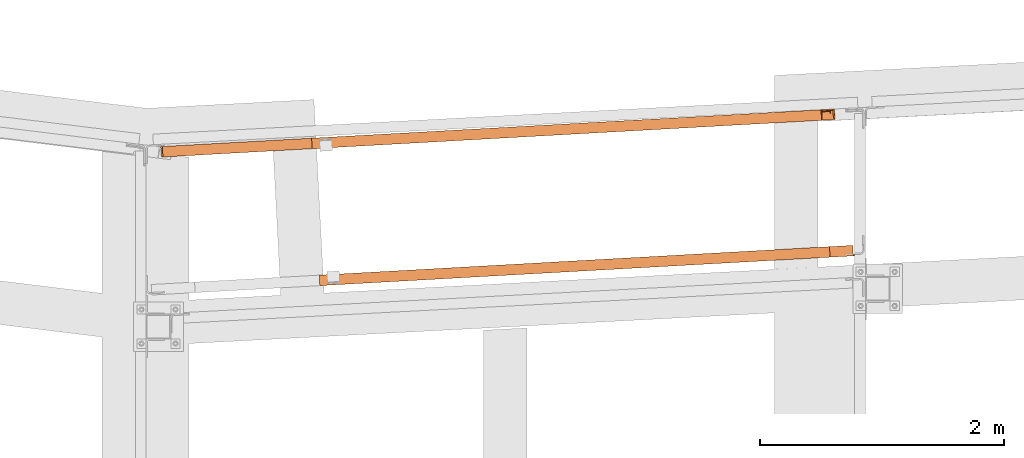
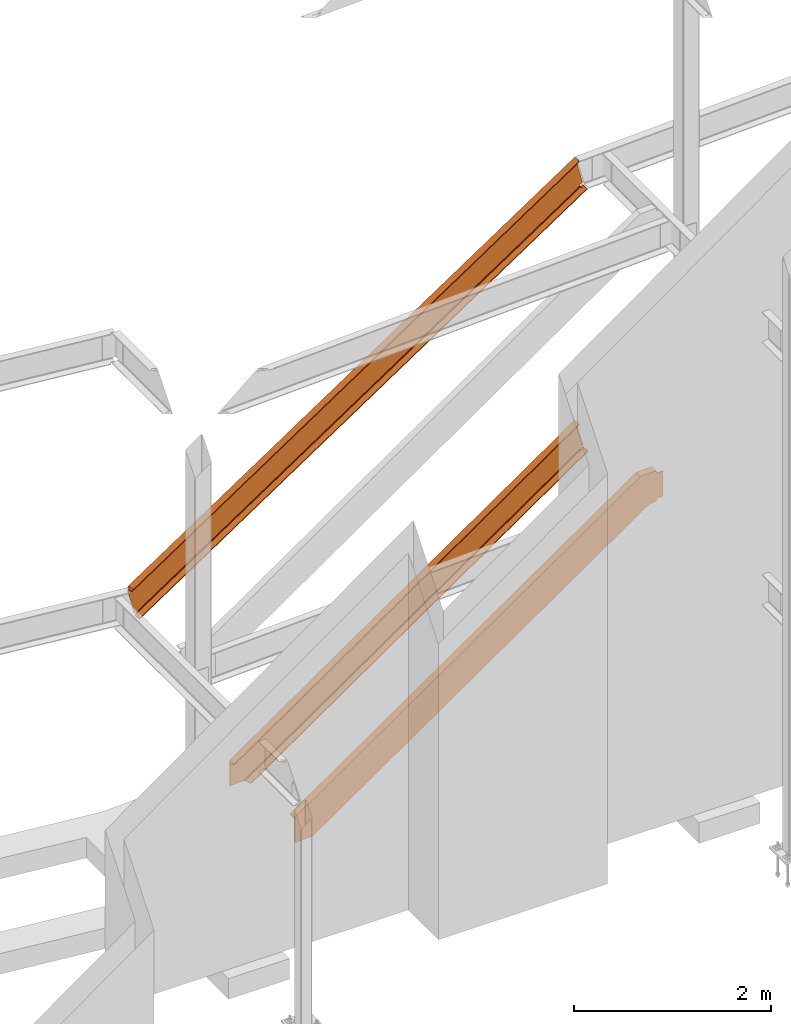
# One storey, part 19 of 89: 3 proxies.
"""IFC4 building model written with IfcOpenShell, lengths in feet."""

from ifc_helpers import new_model, entity, si_unit, converted_unit, derived_unit, direction, frame, origin, place, context, subcontext, project, spatial, face_set, faceted_brep, surface_model, source, transform, mapped, material, constituent, constituent_set, type_object, type_shapes, element, save


model = new_model("IFC4")

# Units and contexts
model_context = context("Model", 3, precision=0.0001, world=origin(), true_north=direction((6.12303176911189e-17, 1.0)))
body_context = subcontext(model_context, "Body", "Model", "MODEL_VIEW")
ifc_project = project(units=[converted_unit("LENGTHUNIT", "FOOT", entity("IfcRatioMeasure", 0.3048), si_unit("LENGTHUNIT", "METRE"), dimensions=[1, 0, 0, 0, 0, 0, 0]), converted_unit("AREAUNIT", "SQUARE FOOT", entity("IfcRatioMeasure", 0.09290304), si_unit("AREAUNIT", "SQUARE_METRE"), dimensions=[2, 0, 0, 0, 0, 0, 0]), converted_unit("VOLUMEUNIT", "CUBIC FOOT", entity("IfcRatioMeasure", 0.028316846592), si_unit("VOLUMEUNIT", "CUBIC_METRE"), dimensions=[3, 0, 0, 0, 0, 0, 0]), si_unit("PLANEANGLEUNIT", "RADIAN"), si_unit("MASSUNIT", "GRAM", prefix="KILO"), derived_unit("MASSDENSITYUNIT", [(si_unit("MASSUNIT", "GRAM", prefix="KILO"), 1), (si_unit("LENGTHUNIT", "METRE"), -3)]), derived_unit("MOMENTOFINERTIAUNIT", [(si_unit("LENGTHUNIT", "METRE"), 4)]), si_unit("TIMEUNIT", "SECOND"), si_unit("FREQUENCYUNIT", "HERTZ"), si_unit("THERMODYNAMICTEMPERATUREUNIT", "DEGREE_CELSIUS"), derived_unit("THERMALTRANSMITTANCEUNIT", [(si_unit("MASSUNIT", "GRAM", prefix="KILO"), 1), (si_unit("THERMODYNAMICTEMPERATUREUNIT", "KELVIN"), -1), (si_unit("TIMEUNIT", "SECOND"), -3)]), derived_unit("VOLUMETRICFLOWRATEUNIT", [(si_unit("LENGTHUNIT", "METRE"), 3), (si_unit("TIMEUNIT", "SECOND"), -1)]), si_unit("ELECTRICCURRENTUNIT", "AMPERE"), si_unit("ELECTRICVOLTAGEUNIT", "VOLT"), si_unit("POWERUNIT", "WATT"), si_unit("FORCEUNIT", "NEWTON"), si_unit("ILLUMINANCEUNIT", "LUX"), si_unit("LUMINOUSFLUXUNIT", "LUMEN"), si_unit("LUMINOUSINTENSITYUNIT", "CANDELA"), derived_unit("USERDEFINED", [(si_unit("MASSUNIT", "GRAM", prefix="KILO"), -1), (si_unit("LENGTHUNIT", "METRE"), -2), (si_unit("TIMEUNIT", "SECOND"), 3), (si_unit("LUMINOUSFLUXUNIT", "LUMEN"), 1)]), derived_unit("LINEARVELOCITYUNIT", [(si_unit("LENGTHUNIT", "METRE"), 1), (si_unit("TIMEUNIT", "SECOND"), -1)]), si_unit("PRESSUREUNIT", "PASCAL"), derived_unit("USERDEFINED", [(si_unit("LENGTHUNIT", "METRE"), -2), (si_unit("MASSUNIT", "GRAM", prefix="KILO"), 1), (si_unit("TIMEUNIT", "SECOND"), -2)]), derived_unit("LINEARFORCEUNIT", [(si_unit("MASSUNIT", "GRAM", prefix="KILO"), 1), (si_unit("LENGTHUNIT", "METRE"), 1), (si_unit("TIMEUNIT", "SECOND"), -2), (si_unit("LENGTHUNIT", "METRE"), -1)]), derived_unit("PLANARFORCEUNIT", [(si_unit("MASSUNIT", "GRAM", prefix="KILO"), 1), (si_unit("LENGTHUNIT", "METRE"), 1), (si_unit("TIMEUNIT", "SECOND"), -2), (si_unit("LENGTHUNIT", "METRE"), -2)])], contexts=[model_context])

# Site, building, storey
site_placement = place(None, origin())
site = spatial("IfcSite", under=ifc_project, at=site_placement, CompositionType="ELEMENT")
building_placement = place(site_placement, frame((-472.238160486, -49.138065117, 0.0)))
building = spatial("IfcBuilding", under=site, at=building_placement, CompositionType="ELEMENT")
storey_placement = place(building_placement, origin())
storey = spatial("IfcBuildingStorey", under=building, at=storey_placement, Name="Level 1", CompositionType="ELEMENT", Elevation=0.0)

# Proxies
ifc_material_1 = material(Name="Color 7720", Category="Materials")
ifc_material_2 = material()
ifc_constituent_1 = constituent(ifc_material_2)
ifc_constituent_2 = constituent(ifc_material_1, Name="Color 7720", Category="Materials")
ifc_constituent_set_1 = constituent_set(constituents=[ifc_constituent_1, ifc_constituent_2])
building_element_proxy_type_1 = type_object("IfcBuildingElementProxyType", Name="65B1", PredefinedType="NOTDEFINED", material=ifc_constituent_set_1)
shared_shape_1 = source(origin(), body_context, "Body", "SurfaceModel", [
    surface_model("IfcFaceBasedSurfaceModel", [(0.295725599131003, 0.298618076192042, 0.010066705292779), (0.298398827761901, 0.29876719922845, 0.0), (0.314179722650067, 0.0158736836889375, 0.0), (0.31150649401917, 0.0157245606525294, 0.010066705292779), (0.264968785703161, 0.263517185083515, 0.132880509864478), (0.00185657586928301, 0.248839767966842, 1.1236947801826), (0.0, 0.282121358030281, 1.1236947801826), (0.263112209833935, 0.296798775146954, 0.132880509864478), (17.7732027645449, 1.27357937755687, 11.858022026967), (17.7608547077558, 1.27289055517133, 11.9045216967659), (17.7766356026439, 0.989997039631817, 11.9045216967659), (17.7834019801254, 0.990374494348544, 11.8790412244943), (17.7819959007779, 1.11595072346483, 11.858022026967), (18.0571214415841, 1.28941745992006, 10.7888558449879), (17.7940092317501, 1.2747400428035, 11.779670115306), (17.7958658076193, 1.24145845274006, 11.779670115306), (18.0589780174533, 1.25613586985662, 10.7888558449879), (18.1055157257693, 1.00834324542575, 10.6660420404161), (18.1081889544002, 1.00849236846204, 10.6559753351234), (18.0924080595121, 1.29138588400156, 10.6559753351234), (18.0897348308811, 1.29123676096526, 10.6660420404161), (17.952139730053, 1.28356117384669, 10.7321324343652), (17.7619914226751, 1.2729539655262, 11.7546720500187), (17.7468636322483, 1.27211007884262, 11.7472027033928), (17.7300183363629, 1.27117038305914, 11.7463622836656), (17.7142242870842, 1.27028932987901, 11.7522889251786), (17.7020774498885, 1.26961173230075, 11.7640085042928), (17.6955743216495, 1.26924896264529, 11.7795947497751), (17.6957837793919, 1.26926064700854, 11.7964858515118), (17.7026713959043, 1.26964486490772, 11.8119055286269), (17.7151050983179, 1.27033846493771, 11.8233193487691), (17.7529728118764, 1.27245087252038, 11.909107345642), (0.0481609911819874, 0.284807964468314, 1.30654804508336), (0.00261789468112283, 0.282267394326936, 1.22773414158754), (0.00529112331201986, 0.282416517363458, 1.21766743629478), (0.0638364013074693, 0.285682399497546, 1.25282444181741), (0.0793525333193656, 0.286547949377223, 1.25833774725961), (0.0957890479889443, 0.287464841762812, 1.25739098436862), (0.110571787677145, 0.288289480180993, 1.25013242770127), (0.121385595973948, 0.288892716249393, 1.23769885530753), (0.126536899284361, 0.289180075879813, 1.22203751549417), (0.125218941003766, 0.289106555067406, 1.20560116411183), (0.117638129391082, 0.288683668063413, 1.19096393322691), (0.104981711531082, 0.287977644104103, 1.18041819080527), (0.295130018908878, 0.298584852424597, 0.157878575151766), (0.310252120444488, 0.299428421759785, 0.165346442812167), (0.327091489879081, 0.300367786942843, 0.16619014985198), (0.342882237877916, 0.301248655964855, 0.160271116242324), (0.355030712603536, 0.30192634489083, 0.148561551304688), (0.361541510557913, 0.302289542392714, 0.132984767007503), (0.361345224320985, 0.302278592786934, 0.116099271359211), (0.354474094174066, 0.301895294561064, 0.100678529987807), (0.342056712590022, 0.301202604970172, 0.0892554206389331), (0.341268695631754, 0.301158646335125, 0.088880608788596), (18.0460805163262, 1.28880155438719, 10.6914399093472), (17.9932897710816, 1.28585668235587, 10.6597290246742), (17.9777736865076, 1.28499113512237, 10.6542135610812), (17.9613363953122, 1.28407419941925, 10.6551585892483), (17.9465523881188, 1.28324949029468, 10.6624160941451), (17.9357372099552, 1.28264617780985, 10.6748493691158), (17.9305847880287, 1.28235875577866, 10.6905110525512), (17.9319021203893, 1.28243224167488, 10.7069481333881), (17.9394828798648, 1.28285512577042, 10.7215861539503), (18.0825023328435, 1.00705946932317, 10.6794311210408), (0.335515602523458, 0.0170638816224482, 0.0516152978580848), (18.0021084937518, 1.12776935737008, 10.6597290246741), (18.054871402101, 1.13121324275153, 10.6914399093471), (0.35005958140664, 0.143570334695823, 0.0888806087887808), (0.35087544796869, 0.143115052166877, 0.089255420639109), (0.362149245725277, 0.164308001823315, 0.100678529987992), (0.365777459588855, 0.222824884645433, 0.116099271359381), (0.365667356573624, 0.224882867314591, 0.116502267115274), (17.9646186250475, 1.2066204641643, 10.655666780207), (17.9659774283279, 1.20087751413507, 10.6551585892481), (17.985509222289, 1.14632137480237, 10.654213561081), (17.9570413472568, 1.22364703771746, 10.6589101283048), (0.364781271167942, 0.24228270146898, 0.123752648146477), (17.9456956444367, 1.23726656409883, 10.6663376948628), (0.362565075016676, 0.256411507056896, 0.136647436656453), (0.364360026038412, 0.251763906266206, 0.13298476700758), (17.9494507520763, 1.23129246408814, 10.6624160941452), (17.9362157395262, 1.24605132842385, 10.6795852555181), (0.354688001843442, 0.265285683537968, 0.150854856061752), (0.357170721441832, 0.263563842139092, 0.148561551304777), (17.9379314981277, 1.24331064584806, 10.6748493691159), (17.9331256234714, 1.24911533636339, 10.6990489358223), (0.338638484670298, 0.267626765939667, 0.162557775040209), (0.34478922504843, 0.267063376322653, 0.160271116242352), (17.9325103468877, 1.24784055393593, 10.6905110525512), (17.9413394557196, 1.24957353596494, 10.7215861539503), (17.9539963059078, 1.25027958404155, 10.7321324343652), (17.7638479985309, 1.23967237570389, 11.7546720500187), (17.7487202081041, 1.23882848901997, 11.7472027033928), (17.7318749122188, 1.23788879323592, 11.7463622836656), (17.7221975030833, 1.23734894990946, 11.7499936851959), (0.127709027826711, 0.255860304436851, 1.21350172405842), (0.12707551688743, 0.255824964745443, 1.20560116411183), (0.119494705274747, 0.255402077741337, 1.19096393322691), (0.106838287414746, 0.254696053781686, 1.18041819080527), (0.296986594791576, 0.265303262119346, 0.157878575151768), (0.312108696327186, 0.266146831454989, 0.165346442812167), (0.328948065761722, 0.267086196638616, 0.16619014985198), (17.9337586962442, 1.24915065186929, 10.7069481333881), (17.7065093281335, 1.23323741600052, 11.7616974341864), (0.124979036085108, 0.252471628622288, 1.23296550504353), (0.128462439435964, 0.254662209392791, 1.22203751549416), (17.7161314299826, 1.23610125860705, 11.7522889251786), (17.6996683184155, 1.22354220790703, 11.7759049678167), (0.116535035054028, 0.242686999470948, 1.24621308436147), (0.123579794613761, 0.249558789283356, 1.23769885530749), (17.7042182206326, 1.2312355713749, 11.7640085042928), (17.6990355348262, 1.20925447520597, 11.7887986985157), (0.10677429795129, 0.227890074204311, 1.25364052321855), (0.113469935967544, 0.236336320096484, 1.2501324277012), (17.6983946965211, 1.21868999446235, 11.7795947497751), (17.7000958529101, 1.19186436042446, 11.7960524737729), (0.101138442234117, 0.210126420938877, 1.25688428241156), (17.7103520069585, 1.13195971243556, 11.8119055277782), (17.7239238253192, 1.11225107143321, 11.8233193479195), (0.0296228440811319, 0.0, 1.24715775758312), (0.0147554209531222, 0.0646860958185016, 1.22773414232155), (0.0140820086414237, 0.124828205841709, 1.21766743702795), (0.0726551259076018, 0.127595032102363, 1.25282444254534), (0.0870874438550118, 0.147889389620673, 1.25833774798595), (0.100429091568628, 0.2042858856571, 1.25739098509289), (17.7002246112936, 1.18965284189335, 11.7964858506631), (17.7687537067645, 0.989557356982345, 11.909107345642), (0.0639418860702676, 0.00191444892675463, 1.30654804508337)], [face_set([[[0, 1, 2, 3]], [[4, 5, 6, 7]], [[8, 9, 10, 11, 12]], [[13, 14, 15, 16]], [[17, 18, 19, 20]], [[21, 13, 14, 22, 23, 24, 25, 26, 27, 28, 29, 30, 8, 9, 31, 32, 33, 34, 35, 36, 37, 38, 39, 40, 41, 42, 43, 6, 7, 44, 45, 46, 47, 48, 49, 50, 51, 52, 53, 0, 1, 19, 20, 54, 55, 56, 57, 58, 59, 60, 61, 62]], [[18, 2, 1, 19]], [[17, 63, 64, 3, 2, 18]], [[65, 66, 63, 64, 67, 68, 69, 70, 71, 72, 73, 74]], [[75, 76, 71, 72]], [[77, 78, 79, 76, 75, 80]], [[81, 82, 83, 78, 77, 84]], [[85, 86, 87, 82, 81, 88]], [[89, 90, 16, 15, 91, 92, 93, 94, 95, 96, 97, 98, 5, 4, 99, 100, 101, 86, 85, 102]], [[103, 104, 105, 95, 94, 106]], [[107, 108, 109, 104, 103, 110]], [[111, 112, 113, 108, 107, 114]], [[115, 116, 112, 111]], [[117, 118, 12, 11, 119, 120, 121, 122, 123, 124, 116, 115, 125]], [[126, 127, 119, 11, 10]], [[31, 32, 127, 126]], [[98, 43, 6, 5]], [[97, 42, 43, 98]], [[96, 41, 42, 97]], [[105, 40, 41, 96, 95]], [[109, 39, 40, 105, 104]], [[113, 38, 39, 109, 108]], [[116, 124, 37, 38, 113, 112]], [[123, 36, 37, 124]], [[36, 123, 122, 35]], [[35, 122, 121, 34]], [[120, 33, 34, 121]], [[127, 32, 33, 120, 119]], [[64, 67, 53, 0, 3]], [[68, 52, 53, 67]], [[69, 51, 52, 68]], [[70, 50, 51, 69]], [[76, 79, 49, 50, 70, 71]], [[83, 48, 49, 79, 78]], [[87, 47, 48, 83, 82]], [[101, 46, 47, 87, 86]], [[46, 101, 100, 45]], [[45, 100, 99, 44]], [[44, 99, 4, 7]], [[31, 126, 10, 9]], [[118, 30, 8, 12]], [[117, 29, 30, 118]], [[125, 28, 29, 117]], [[111, 114, 27, 28, 125, 115]], [[110, 26, 27, 114, 107]], [[106, 25, 26, 110, 103]], [[93, 24, 25, 106, 94]], [[24, 93, 92, 23]], [[23, 92, 91, 22]], [[22, 91, 15, 14]], [[16, 90, 21, 13]], [[89, 62, 21, 90]], [[102, 61, 62, 89]], [[88, 60, 61, 102, 85]], [[84, 59, 60, 88, 81]], [[80, 58, 59, 84, 77]], [[72, 73, 57, 58, 80, 75]], [[74, 56, 57, 73]], [[56, 74, 65, 55]], [[55, 65, 66, 54]], [[54, 66, 63, 17, 20]]])]),
])
type_shapes(building_element_proxy_type_1, [shared_shape_1])
proxy_1_placement = place(building_placement, frame((288.890091003621, 1017.17702823538, 8.3475913766196)))
element("IfcBuildingElementProxy", 1, at=proxy_1_placement, inside=storey, type_object=building_element_proxy_type_1, material=ifc_material_1, Name="65B1:65B1", ObjectType="65B1:65B1", PredefinedType="NOTDEFINED", context=body_context, shape_type="MappedRepresentation", body=[
    mapped(shared_shape_1, transform((0.0, 0.0, 0.0), scale=1.0)),
])
ifc_constituent_3 = constituent(ifc_material_2)
ifc_constituent_4 = constituent(ifc_material_1, Name="Color 7720", Category="Materials")
ifc_constituent_set_2 = constituent_set(constituents=[ifc_constituent_3, ifc_constituent_4])
building_element_proxy_type_2 = type_object("IfcBuildingElementProxyType", Name="c644", PredefinedType="NOTDEFINED", material=ifc_constituent_set_2)
shared_shape_2 = source(origin(), body_context, "Body", "Brep", [
    faceted_brep([(0.0, 0.28289351553849, 2.09684300217347e-07), (0.707232670482711, 0.322345690372117, 0.0), (0.723013565370877, 0.0394521748326042, 0.0), (0.66014500999637, 0.0359451235583492, 1.86396251559168e-08), (0.583988115515638, 0.237833801498596, 3.78203000407731e-08), (0.571363060839417, 0.25457879052567, 4.12757467593667e-08), (0.548317314991891, 0.267545643236417, 4.78734869618808e-08), (0.517667660340578, 0.275149477009677, 5.68071072481707e-08), (0.483160272312603, 0.276460907956448, 6.69846896448543e-08), (0.0018565758705904, 0.249611925475051, 2.09684300217337e-07), (13.7015000332585, 1.04721620219675, 9.58515138815906), (13.7172809281467, 0.764322686657238, 9.58515138815906), (13.7245293535907, 0.764727031874486, 9.55980424557848), (13.7235209223415, 0.89032544334043, 9.53889503357592), (13.7147277861084, 1.04795409743247, 9.53889503357592), (13.7370165405719, 1.04919745039751, 9.46095310788648), (13.7388731164411, 1.01591586033408, 9.46095310788648), (14.0207298768163, 1.03163892100781, 8.47532339455757), (14.0188733009471, 1.06492051107125, 8.47532339455757), (14.0724546909929, 0.784135653411909, 8.34313819823145), (14.0566737961047, 1.06702916895142, 8.34313819823145), (14.0538101222292, 1.0668694221423, 8.35315222825614), (14.0695910171173, 0.783975906602791, 8.35315222825614), (0.0, 0.282893515534738, 1.03139765914798), (13.6935325870149, 1.04677174721212, 9.58958625447321), (13.6572987822075, 1.044750485382, 9.50309329352722), (13.6450838005694, 1.04406908644319, 9.49144497836934), (13.6384898801842, 1.04370125205048, 9.47589704478433), (13.638600820993, 1.04370744075823, 9.45900500580773), (13.6453983883741, 1.04408663536844, 9.44354529636364), (13.6577653102505, 1.04477651012178, 9.43205892865757), (13.6736689158564, 1.04566367477798, 9.42643384247552), (13.6904952326522, 1.04660231183448, 9.42759459676199), (13.7054786280426, 1.04743814360415, 9.4353504058608), (13.9149863618575, 1.05912529564591, 8.41661291406195), (13.9025318187382, 1.05843053304079, 8.40582773665138), (13.8952300553685, 1.05802321242754, 8.39104813135308), (13.8942247103873, 1.05796713039467, 8.37458895374796), (13.8996732459455, 1.05827107079006, 8.35902812241832), (13.9107222851978, 1.05888742895138, 8.34680285246703), (13.9256412724452, 1.05971966778577, 8.33982792671845), (13.9420935214098, 1.06063743789127, 8.33919579287125), (13.9575021987077, 1.06149699353136, 8.34500545888511), (14.0096819822679, 1.064407783756, 8.37771497966131), (14.0463278360467, 0.782678196351299, 8.36610105714485), (13.9498290571924, 0.921967677565476, 8.33919579286976), (13.930282305462, 0.976522982496135, 8.33982792671693), (13.9289140504977, 0.982265405273779, 8.34031633068702), (14.0184728680439, 0.906819472114421, 8.37771497965982), (13.9663209213792, 0.903409668539894, 8.34500545888362), (13.9212764506935, 0.999288613831254, 8.34343339536561), (13.9136206491556, 1.00693040273916, 8.34680285246704), (13.9097917789864, 1.0129003879905, 8.35065884596249), (13.9018675341184, 1.0189355388228, 8.35902812241835), (13.9000622346622, 1.02167122646335, 8.36373351247461), (13.8961502692466, 1.0234489285466, 8.37458895374795), (13.8966034907883, 1.02471467091675, 8.38313831470354), (13.897086631238, 1.02474162236012, 8.39104813135308), (13.9043883946076, 1.02514894297337, 8.40582773665138), (13.916842937727, 1.0258437055785, 8.41661291406195), (13.7073352039116, 1.01415655354469, 9.43535040586081), (13.6923518085212, 1.01332072177502, 9.42759459676199), (13.6755254917254, 1.01238208471864, 9.42643384247552), (13.6657809546873, 1.01183849673839, 9.42988047351011), (0.00185657589133825, 0.249611925476302, 0.890196426087728), (13.6596724531487, 1.01058843885266, 9.43205892865759), (13.6498736667378, 1.0077147400973, 9.44128021493225), (0.0020365539935483, 0.246385578781656, 0.911650392449921), (13.6475391591181, 1.00571047444532, 9.44354529636368), (13.6427645212826, 0.998004574355377, 9.45534517913227), (0.00255449035103084, 0.237100881174456, 0.930482132802914), (13.6414211958643, 0.993148472578127, 9.45900500580786), (13.641887449238, 0.983703214298657, 9.46820946524984), (0.00334707983131466, 0.222892661297919, 0.944389924541088), (13.64281017422, 0.966305424041593, 9.47546364299847), (0.00431744763176312, 0.205497528741716, 0.951673878114343), (13.64293071157, 0.964093447074447, 9.47589704478425), (13.6527644111075, 0.906383934110295, 9.49144497836934), (13.6661175086923, 0.886663092016988, 9.50309329352724), (0.0157808949101081, 0.0, 0.992106029655508), (13.7093134819028, 0.763878231677495, 9.58958625447321), (0.0157808949102787, 0.0, 1.03139765914798)], [[[0, 1, 2, 3, 4, 5, 6, 7, 8, 9]], [[10, 11, 12, 13, 14]], [[15, 16, 17, 18]], [[19, 20, 21, 22]], [[23, 24, 10, 14, 25, 26, 27, 28, 29, 30, 31, 32, 33, 15, 18, 34, 35, 36, 37, 38, 39, 40, 41, 42, 43, 21, 20, 1, 0]], [[2, 1, 20, 19]], [[44, 3, 2, 19, 22]], [[45, 46, 47, 4, 3, 44, 48, 49]], [[5, 4, 47, 50]], [[6, 5, 50, 51, 52]], [[7, 6, 52, 53, 54]], [[8, 7, 54, 55, 56]], [[9, 8, 56, 57, 58, 59, 17, 16, 60, 61, 62, 63, 64]], [[64, 63, 65, 66, 67]], [[67, 66, 68, 69, 70]], [[70, 69, 71, 72, 73]], [[73, 72, 74, 75]], [[75, 74, 76, 77, 78, 13, 12, 79]], [[79, 12, 11, 80, 81]], [[81, 80, 24, 23]], [[80, 11, 10, 24]], [[78, 25, 14, 13]], [[26, 25, 78, 77]], [[27, 26, 77, 76]], [[72, 71, 28, 27, 76, 74]], [[29, 28, 71, 69, 68]], [[30, 29, 68, 66, 65]], [[31, 30, 65, 63, 62]], [[62, 61, 32, 31]], [[61, 60, 33, 32]], [[60, 16, 15, 33]], [[59, 34, 18, 17]], [[35, 34, 59, 58]], [[36, 35, 58, 57]], [[37, 36, 57, 56, 55]], [[38, 37, 55, 54, 53]], [[39, 38, 53, 52, 51]], [[46, 40, 39, 51, 50, 47]], [[41, 40, 46, 45]], [[45, 49, 42, 41]], [[43, 42, 49, 48]], [[48, 44, 22, 21, 43]], [[64, 9, 0, 23, 81, 79, 75, 73, 70, 67]]]),
])
type_shapes(building_element_proxy_type_2, [shared_shape_2])
proxy_2_placement = place(building_placement, frame((292.94980356775, 1017.40272255283, -6.98970639589902e-07)))
element("IfcBuildingElementProxy", 2, at=proxy_2_placement, inside=storey, type_object=building_element_proxy_type_2, material=ifc_material_1, Name="c644:c644", ObjectType="c644:c644", PredefinedType="NOTDEFINED", context=body_context, shape_type="MappedRepresentation", body=[
    mapped(shared_shape_2, transform((0.0, 0.0, 0.0), scale=1.0)),
])
ifc_constituent_5 = constituent(ifc_material_1, Name="Color 7720", Category="Materials")
ifc_material_3 = material(Name="Color 7718", Category="Materials")
ifc_constituent_6 = constituent(ifc_material_3, Name="Color 7718", Category="Materials")
ifc_constituent_set_3 = constituent_set(constituents=[ifc_constituent_5, ifc_constituent_6])
ifc_constituent_7 = constituent(ifc_material_2)
ifc_constituent_8 = constituent(ifc_material_3, Name="Color 7718", Category="Materials")
ifc_constituent_set_4 = constituent_set(constituents=[ifc_constituent_7, ifc_constituent_8])
building_element_proxy_type_3 = type_object("IfcBuildingElementProxyType", Name="c645", PredefinedType="NOTDEFINED", material=ifc_constituent_set_4)
shared_shape_3 = source(origin(), body_context, "Body", "SurfaceModel", [
    surface_model("IfcFaceBasedSurfaceModel", [(0.0139243190023421, 0.0332815900634387, 2.0962485751345e-07), (0.0157808948715683, 0.0, 2.0962485751345e-07), (0.722813025380788, 0.0394409879380646, 0.0), (0.707032130492621, 0.322334503477578, 0.0), (0.644163575118114, 0.318827452203323, 1.86396365327711e-08), (0.590933575194526, 0.109721072660591, 3.78203117321731e-08), (0.580249256119316, 0.0916757965750321, 4.12757585073935e-08), (0.558788689232017, 0.0762262095331607, 4.78734988180961e-08), (0.529174907295783, 0.0652606480915665, 5.68071192508571e-08), (0.495027475472227, 0.0601193856492728, 6.69847018144127e-08), (14.0899012045054, 0.785108887443016, 8.35416725965628), (14.0741203096172, 1.06800240298253, 8.35416725965628), (14.0645878963288, 1.06747064808587, 8.38750131829038), (14.0662422320077, 0.861425929145184, 8.42180296796932), (14.0654454637354, 0.843932218901159, 8.42798249624639), (14.0628639295029, 0.829535777348838, 8.43978152701347), (14.0588131591333, 0.819996219602558, 8.45575791550159), (14.0537882608616, 0.816479524764759, 8.47395893647947), (13.7648432457193, 0.800361053813958, 9.48437568881402), (13.7594583912431, 0.803297052365224, 9.5025767097919), (13.7543717481585, 0.812326889833798, 9.51855309828003), (13.7502050349657, 0.826346888034095, 9.5303521290471), (13.7474675310925, 0.843643442902817, 9.53653165732417), (13.7261949722142, 1.04859378144511, 9.5708333070031), (13.7166625589257, 1.04806202654845, 9.60416736563718), (13.7324434538139, 0.765168511008937, 9.60416736563718), (0.0, 0.28289351554065, 1.03152299268716), (0.0, 0.282893515540536, 0.992231363194528), (0.0114634472827788, 0.0773959867992744, 0.951799211653507), (0.0124338150832273, 0.0600008542429578, 0.944515258080141), (0.0132264045633406, 0.0457926343665349, 0.930607466341959), (0.0137443409208799, 0.0365079367591079, 0.911775725989016), (0.0139243190231468, 0.0332815900646892, 0.890321759626922), (0.015780894892373, 0.0, 1.03152299268715)], [face_set([[[0, 1, 2, 3, 4, 5, 6, 7, 8, 9]], [[10, 11, 12, 13, 14, 15, 16, 17, 18, 19, 20, 21, 22, 23, 24, 25]], [[26, 24, 23, 27]], [[27, 23, 22, 28]], [[28, 22, 21, 29]], [[29, 21, 20, 30]], [[30, 20, 19, 31]], [[31, 19, 18, 32]], [[32, 18, 17, 9, 0]], [[8, 9, 17, 16]], [[7, 8, 16, 15]], [[6, 7, 15, 14]], [[5, 6, 14, 13]], [[4, 5, 13, 12]], [[3, 4, 12, 11]], [[2, 3, 11, 10]], [[1, 2, 10, 25, 33]], [[33, 25, 24, 26]], [[33, 26, 27, 28, 29, 30, 31, 32, 0, 1]]])]),
    surface_model("IfcFaceBasedSurfaceModel", [(14.6290229317798, 0.815186160448206, 8.46875069897065), (14.6271613595142, 0.848450320604456, 8.47395871441254), (14.6290229317798, 0.815186160448206, 9.48958371441254), (14.6271613595142, 0.848572390916956, 8.46875069897065), (14.6271613595142, 0.848572390916956, 9.48484490673432), (14.6271613595142, 0.848572390916956, 9.48958371441254), (13.7166694161548, 1.04803528154196, 9.60416768352876), (13.7261909005298, 1.04858459794821, 9.57083295147309), (13.7474616524829, 0.843628543260706, 9.53653119366059), (13.7502082345142, 0.826355594041956, 9.5303523377646), (13.7324470040454, 0.765198367479456, 9.60416768352876), (13.7543586251392, 0.812317508104456, 9.51855347912202), (13.759455060686, 0.803284304979456, 9.50257657329926), (13.7648566720142, 0.800354617479456, 9.48437569897065), (14.0537971017017, 0.816467898729456, 8.47395871441254), (14.0654548165454, 0.843933719041956, 8.42798302929292), (14.0662482735767, 0.861450808885706, 8.4218032197226), (14.0898993966235, 0.785095828416956, 8.35416768352876), (14.0646003243579, 1.06744446122946, 8.3875014619101), (14.0741218087329, 1.06799377763571, 8.35416768352876), (14.0588019845142, 0.820007937791956, 8.45575784008393), (14.0628608224048, 0.829529422166956, 8.43978188793549), (14.3586066720142, 0.800110476854456, 9.53125069897065), (14.3586066720142, 0.800110476854456, 9.60416768352876), (14.361749982561, 0.800293582323206, 9.51530526440034), (14.370783185686, 0.800781863573206, 9.5017878846396), (14.4002021309985, 0.802429812791956, 8.46875069897065), (14.4002021309985, 0.802429812791956, 9.48958371441254), (14.3842719552173, 0.801514285448206, 9.49275563518891), (14.370783185686, 0.800781863573206, 8.4565465287436), (14.361749982561, 0.800293582323206, 8.44302914898286), (14.3586066720142, 0.800110476854456, 8.42708371441254), (14.3586066720142, 0.800110476854456, 8.35416768352876), (14.3842719552173, 0.801514285448206, 8.46557877819428), (14.3428290841235, 1.08300842607321, 8.35416768352876), (14.354425763811, 0.875061648729456, 8.35416768352876), (14.3428290841235, 1.08300842607321, 8.3875014619101), (14.3542731759204, 0.877503054979456, 8.4218032197226), (14.354425763811, 0.875061648729456, 8.42266629497895), (14.3550971505298, 0.862610476854456, 8.42708371441254), (14.3554328438892, 0.860108035448206, 8.42798302929292), (14.358576154436, 0.846008914354456, 8.43978188793549), (14.359308576311, 0.844177859666956, 8.44302914898286), (14.3682197091235, 0.837280887010706, 8.45575784008393), (14.3687385079517, 0.837158816698206, 8.4565465287436), (14.3823493477954, 0.836304324510706, 8.46557877819428), (14.3931525704517, 0.836548465135706, 8.46772740642915), (14.3983405587329, 0.835755008104456, 8.47348950664887), (14.3931525704517, 0.836548465135706, 9.49060700695405), (14.3983405587329, 0.835755008104456, 9.48484490673432), (14.3823493477954, 0.836304324510706, 9.49275563518891), (14.3687385079517, 0.837158816698206, 9.5017878846396), (14.3682197091235, 0.837280887010706, 9.50257657329926), (14.359308576311, 0.844177859666956, 9.51530526440034), (14.358576154436, 0.846008914354456, 9.51855347912202), (14.3554328438892, 0.860108035448206, 9.5303523377646), (14.3550971505298, 0.862610476854456, 9.53125069897065), (14.354425763811, 0.875061648729456, 9.53566907207856), (14.3542731759204, 0.877503054979456, 9.53653119366059), (14.3428290841235, 1.08300842607321, 9.57083295147309), (14.3428290841235, 1.08300842607321, 9.60416768352876), (14.354425763811, 0.875061648729456, 9.60416768352876), (14.3983405587329, 0.835755008104456, 9.48958371441254), (14.3983405587329, 0.835755008104456, 8.46875069897065)], [face_set([[[0, 1, 2]], [[1, 0, 3]], [[4, 2, 1]], [[2, 4, 5]], [[6, 7, 8]], [[8, 9, 10]], [[6, 8, 10]], [[10, 11, 12]], [[11, 10, 9]], [[12, 13, 10]], [[10, 13, 14]], [[15, 16, 17]], [[18, 19, 16]], [[16, 19, 17]], [[14, 20, 17]], [[21, 17, 20]], [[17, 21, 15]], [[14, 17, 10]], [[22, 23, 10]], [[24, 10, 25]], [[10, 24, 22]], [[26, 27, 28]], [[28, 25, 29]], [[2, 27, 0]], [[17, 25, 10]], [[30, 29, 17]], [[31, 17, 32]], [[17, 31, 30]], [[33, 28, 29]], [[26, 0, 27]], [[26, 28, 33]], [[29, 25, 17]], [[19, 34, 35]], [[35, 32, 17]], [[35, 17, 19]], [[36, 34, 19]], [[19, 18, 36]], [[37, 36, 18]], [[18, 16, 37]], [[38, 37, 16]], [[39, 16, 15]], [[16, 39, 38]], [[39, 15, 40]], [[41, 40, 15]], [[15, 21, 41]], [[42, 41, 21]], [[42, 20, 43]], [[20, 42, 21]], [[20, 14, 43]], [[44, 43, 14]], [[14, 45, 44]], [[46, 45, 47]], [[1, 47, 14]], [[45, 14, 47]], [[14, 13, 4]], [[4, 1, 14]], [[48, 49, 50]], [[4, 13, 49]], [[50, 13, 51]], [[13, 50, 49]], [[13, 52, 51]], [[52, 13, 12]], [[53, 52, 12]], [[54, 12, 11]], [[12, 54, 53]], [[55, 54, 11]], [[11, 9, 55]], [[55, 56, 9]], [[9, 56, 57]], [[58, 8, 9]], [[58, 9, 57]], [[59, 58, 8]], [[8, 7, 59]], [[60, 59, 7]], [[7, 6, 60]], [[61, 6, 10]], [[6, 61, 60]], [[61, 10, 23]], [[5, 62, 27]], [[27, 2, 5]], [[27, 62, 48]], [[48, 50, 28]], [[48, 28, 27]], [[51, 25, 50]], [[28, 50, 25]], [[53, 24, 52]], [[52, 25, 51]], [[25, 52, 24]], [[55, 56, 22]], [[54, 55, 22]], [[53, 22, 24]], [[22, 53, 54]], [[61, 56, 57]], [[23, 22, 56]], [[57, 58, 61]], [[59, 60, 61]], [[23, 56, 61]], [[61, 58, 59]], [[48, 62, 49]], [[4, 49, 62]], [[62, 5, 4]], [[35, 39, 38]], [[32, 31, 39]], [[38, 37, 35]], [[36, 34, 35]], [[32, 39, 35]], [[35, 37, 36]], [[40, 41, 31]], [[39, 40, 31]], [[42, 30, 31]], [[42, 31, 41]], [[44, 29, 43]], [[43, 30, 42]], [[30, 43, 29]], [[29, 44, 45]], [[45, 33, 29]], [[45, 46, 33]], [[26, 33, 46]], [[26, 46, 63]], [[63, 3, 26]], [[0, 26, 3]], [[47, 63, 46]], [[63, 47, 3]], [[1, 3, 47]]])]),
])
type_shapes(building_element_proxy_type_3, [shared_shape_3])
proxy_3_placement = place(building_placement, frame((293.155187273298, 1013.72094665205, -6.98970650248043e-07)))
element("IfcBuildingElementProxy", 3, at=proxy_3_placement, inside=storey, type_object=building_element_proxy_type_3, material=ifc_constituent_set_3, Name="c645:c645", ObjectType="c645:c645", PredefinedType="NOTDEFINED", context=body_context, shape_type="MappedRepresentation", body=[
    mapped(shared_shape_3, transform((0.0, 0.0, 0.0), scale=1.0)),
])

save(model, "model.ifc")
